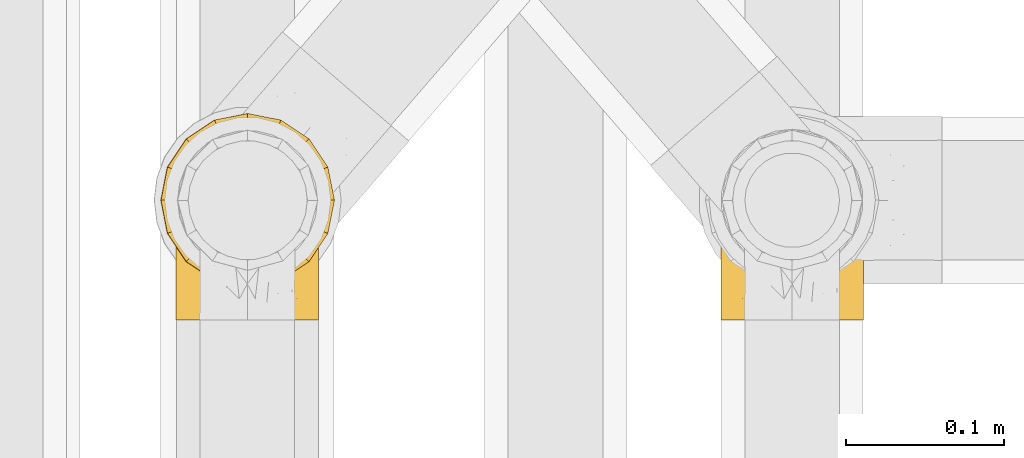
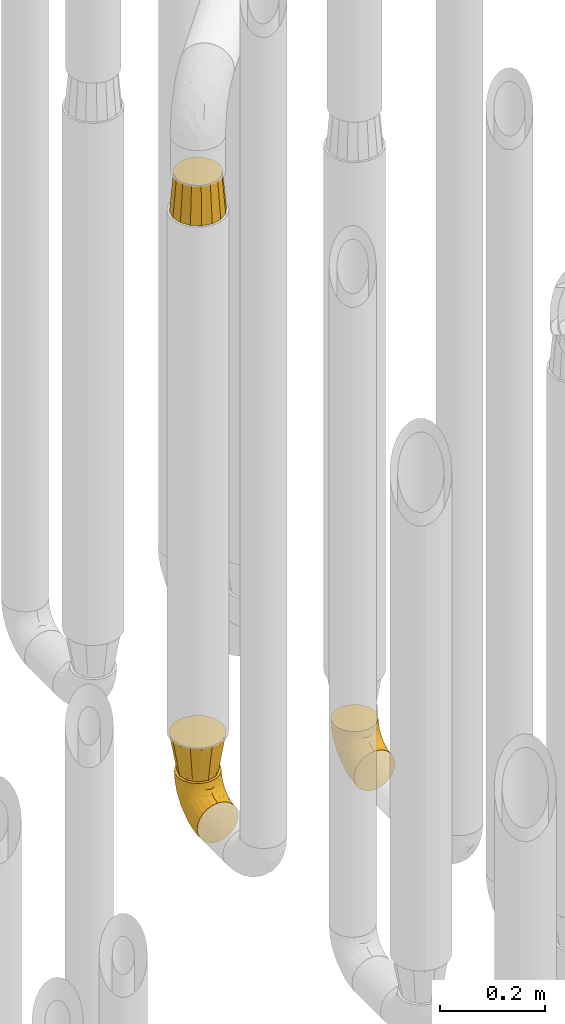
# One storey, part 229 of 827: 4 coverings.
"""IFC2X3 building model written with IfcOpenShell, lengths in millimetres."""

import ifcopenshell
import ifcopenshell.guid

model = None  # the IFC model being written
_history = None  # IfcOwnerHistory: only IFC2X3 demands one
_inside = {}  # id of a spatial element -> (the spatial element, [elements in it])
_under = {}  # id of a project, library or spatial element -> (it, [spatial elements below it])
_declared = {}  # id of a project -> (the project, [libraries it declares])
_typed = {}  # id of a type object -> (the type object, [elements of that type])
_made_of = {}  # id of a material, layer set ... -> (it, [elements and type objects made of it])


def new_model(schema):
    """Start an empty IFC model of exactly this schema.

    Asked for "IFC4X3", IfcOpenShell would pick the latest addendum, in which some entities
    have other attributes; the version numbers below select the first issue.
    IFC2X3 requires an IfcOwnerHistory on every rooted entity: one is made here for all.
    """
    global model, _history
    if schema == "IFC4X3":
        model = ifcopenshell.file(schema_version=(4, 3, 0, 0))
    else:
        model = ifcopenshell.file(schema=schema)
    _inside.clear()
    _under.clear()
    _declared.clear()
    _typed.clear()
    _made_of.clear()
    _history = None
    if model.schema == "IFC2X3":
        org = make("IfcOrganization", Name="unknown")
        user = make(
            "IfcPersonAndOrganization",
            ThePerson=make("IfcPerson", FamilyName="unknown"),
            TheOrganization=org,
        )
        app = make(
            "IfcApplication",
            ApplicationDeveloper=org,
            Version="unknown",
            ApplicationFullName="unknown",
            ApplicationIdentifier="unknown",
        )
        _history = make(
            "IfcOwnerHistory",
            OwningUser=user,
            OwningApplication=app,
            ChangeAction="ADDED",
            CreationDate=0,
        )
    return model


def make(cls, **values):
    """One entity of the class cls with the attributes given. An attribute that is None is left unset."""
    return model.create_entity(
        cls, **{name: value for name, value in values.items() if value is not None}
    )


def entity(cls, *values):
    """Any entity or typed value of the class cls, its attributes in the order of the schema. None: left unset."""
    e = model.create_entity(cls)
    for i, value in enumerate(values):
        if value is not None:
            e[i] = value
    return e


def rooted(cls, **values):
    """An entity with a GlobalId (a new one), such as an element, a storey or a relation."""
    return make(cls, GlobalId=ifcopenshell.guid.new(), OwnerHistory=_history, **values)


def si_unit(unit_type, name, prefix=None):
    """IfcSIUnit, for example si_unit("LENGTHUNIT", "METRE", prefix="MILLI")."""
    return make("IfcSIUnit", UnitType=unit_type, Prefix=prefix, Name=name)


def converted_unit(unit_type, name, factor, base, dimensions=None, offset=None):
    """IfcConversionBasedUnit, such as the inch: factor (a typed value) times the base unit."""
    return make(
        "IfcConversionBasedUnit"
        if offset is None
        else "IfcConversionBasedUnitWithOffset",
        ConversionOffset=offset,
        Dimensions=None
        if dimensions is None
        else entity("IfcDimensionalExponents", *dimensions),
        UnitType=unit_type,
        Name=name,
        ConversionFactor=make(
            "IfcMeasureWithUnit", ValueComponent=factor, UnitComponent=base
        ),
    )


def derived_unit(unit_type, elements):
    """IfcDerivedUnit: a product of units, each with its exponent."""
    return make(
        "IfcDerivedUnit",
        Elements=[
            make("IfcDerivedUnitElement", Unit=unit, Exponent=power)
            for unit, power in elements
        ],
        UnitType=unit_type,
    )


def assignment(units):
    """IfcUnitAssignment: the units of a project."""
    return None if units is None else make("IfcUnitAssignment", Units=units)


def point(xyz):
    """IfcCartesianPoint."""
    return None if xyz is None else make("IfcCartesianPoint", Coordinates=xyz)


def direction(xyz):
    """IfcDirection."""
    return None if xyz is None else make("IfcDirection", DirectionRatios=xyz)


def frame(location, z_axis=None, x_axis=None):
    """IfcAxis2Placement3D, a coordinate frame: its origin and axes. An axis left out is left unset."""
    return make(
        "IfcAxis2Placement3D",
        Location=point(location),
        Axis=direction(z_axis),
        RefDirection=direction(x_axis),
    )


def origin():
    """The frame at (0, 0, 0) with its axes left unset."""
    return frame((0.0, 0.0, 0.0))


def place(relative_to, where):
    """IfcLocalPlacement: puts the frame where relative to a parent placement (None: the world)."""
    return make(
        "IfcLocalPlacement", PlacementRelTo=relative_to, RelativePlacement=where
    )


def context(
    kind, dimensions, precision=None, world=None, true_north=None, identifier=None
):
    """IfcGeometricRepresentationContext, for example the 3D "Model" context."""
    return make(
        "IfcGeometricRepresentationContext",
        ContextIdentifier=identifier,
        ContextType=kind,
        CoordinateSpaceDimension=dimensions,
        Precision=precision,
        WorldCoordinateSystem=world,
        TrueNorth=true_north,
    )


def subcontext(parent, identifier, kind, view, scale=None):
    """IfcGeometricRepresentationSubContext, for example "Body" below "Model"."""
    return make(
        "IfcGeometricRepresentationSubContext",
        ContextIdentifier=identifier,
        ContextType=kind,
        ParentContext=parent,
        TargetScale=scale,
        TargetView=view,
    )


def project(units=None, contexts=None):
    """IfcProject with its units and contexts."""
    return rooted(
        "IfcProject",
        Name="project",
        RepresentationContexts=contexts,
        UnitsInContext=assignment(units),
    )


def spatial(cls, under=None, at=None, **own):
    """A site, building, storey or space (cls), placed at a placement, below another one or the project."""
    s = rooted(cls, ObjectPlacement=at, **own)
    if under is not None:
        _under.setdefault(under.id(), (under, []))[1].append(s)
    return s


def faces_of(points, faces, orient=None, outer=None):
    """IfcFace entities. A face is a list of loops; a loop is a list of indices into points, from 0.

    orient and outer hold one flag for each loop. By default every Orientation is true, the
    first loop of a face is its IfcFaceOuterBound and the others are IfcFaceBound.
    """
    made = []
    for i, loops in enumerate(faces):
        bounds = []
        for j, loop in enumerate(loops):
            is_outer = j == 0 if outer is None else outer[i][j]
            bounds.append(
                make(
                    "IfcFaceOuterBound" if is_outer else "IfcFaceBound",
                    Bound=make("IfcPolyLoop", Polygon=[points[k] for k in loop]),
                    Orientation=True if orient is None else orient[i][j],
                )
            )
        made.append(make("IfcFace", Bounds=bounds))
    return made


def faceted_brep(points, faces, orient=None, outer=None, voids=None):
    """IfcFacetedBrep: a solid bounded by flat faces; with voids (closed shells), ...WithVoids."""
    shared = [point(p) for p in points]
    hull = make("IfcClosedShell", CfsFaces=faces_of(shared, faces, orient, outer))
    if voids is None:
        return make("IfcFacetedBrep", Outer=hull)
    return make(
        "IfcFacetedBrepWithVoids",
        Outer=hull,
        Voids=[
            make(cls, CfsFaces=faces_of(shared, fs, o, b)) for cls, fs, o, b in voids
        ],
    )


def shape(context_of_items, identifier, shape_type, items):
    """IfcShapeRepresentation: the items that make up one representation, for example the "Body"."""
    return make(
        "IfcShapeRepresentation",
        ContextOfItems=context_of_items,
        RepresentationIdentifier=identifier,
        RepresentationType=shape_type,
        Items=items,
    )


def made_of(thing, what):
    """Note that an element or type object is made of a material, layer set ...; save() writes the relation."""
    if what is not None:
        _made_of.setdefault(what.id(), (what, []))[1].append(thing)
    return thing


def element(
    cls,
    number,
    at=None,
    inside=None,
    cuts=None,
    type_object=None,
    material=None,
    context=None,
    identifier="Body",
    shape_type=None,
    held_by="IfcProductDefinitionShape",
    body=None,
    shapes=None,
    **own,
):
    """One element of the class cls, such as IfcWall. Its Tag is "e" and its number.

    at: its placement. inside: the storey or other place that contains it. cuts: it is an
    opening in that element (IfcRelVoidsElement). A single representation is given by context,
    identifier, shape_type and body (its items); several are given by shapes. held_by: the class
    of the entity that holds the representations. save() writes the other relations.
    """
    e = rooted(cls, Tag="e%d" % number, ObjectPlacement=at, **own)
    if body is not None:
        shapes = [shape(context, identifier, shape_type, body)]
    if shapes is not None:
        e.Representation = make(held_by, Representations=shapes)
    if inside is not None:
        _inside.setdefault(inside.id(), (inside, []))[1].append(e)
    if cuts is not None:
        rooted(
            "IfcRelVoidsElement", RelatingBuildingElement=cuts, RelatedOpeningElement=e
        )
    if type_object is not None:
        _typed.setdefault(type_object.id(), (type_object, []))[1].append(e)
    return made_of(e, material)


def aggregate(whole, parts):
    """IfcRelAggregates: a whole, such as a stair, and the parts it consists of."""
    return rooted("IfcRelAggregates", RelatingObject=whole, RelatedObjects=parts)


def save(model, path):
    """Write the relations noted so far, then the file.

    IfcRelAggregates (storeys below a building ...), IfcRelContainedInSpatialStructure (elements
    in a storey), IfcRelDefinesByType, IfcRelAssociatesMaterial and IfcRelDeclares: one each for
    every whole, place, type object, material and project.
    """
    for whole, parts in _under.values():
        aggregate(whole, parts)
    for where, things in _inside.values():
        rooted(
            "IfcRelContainedInSpatialStructure",
            RelatedElements=things,
            RelatingStructure=where,
        )
    for kind, things in _typed.values():
        rooted("IfcRelDefinesByType", RelatedObjects=things, RelatingType=kind)
    for what, things in _made_of.values():
        rooted("IfcRelAssociatesMaterial", RelatedObjects=things, RelatingMaterial=what)
    for by, libraries in _declared.values():
        rooted("IfcRelDeclares", RelatingContext=by, RelatedDefinitions=libraries)
    model.write(path)


model = new_model("IFC2X3")

# Units and contexts
model_context = context("Model", 3, precision=0.01, world=origin(), true_north=direction((6.12303176911189e-17, 1.0)))
body_context = subcontext(model_context, "Body", "Model", "MODEL_VIEW")
ifc_project = project(units=[si_unit("LENGTHUNIT", "METRE", prefix="MILLI"), si_unit("AREAUNIT", "SQUARE_METRE"), si_unit("VOLUMEUNIT", "CUBIC_METRE"), converted_unit("PLANEANGLEUNIT", "DEGREE", entity("IfcRatioMeasure", 0.0174532925199433), si_unit("PLANEANGLEUNIT", "RADIAN"), dimensions=[0, 0, 0, 0, 0, 0, 0]), si_unit("MASSUNIT", "GRAM", prefix="KILO"), derived_unit("MASSDENSITYUNIT", [(si_unit("MASSUNIT", "GRAM", prefix="KILO"), 1), (si_unit("LENGTHUNIT", "METRE"), -3)]), derived_unit("MOMENTOFINERTIAUNIT", [(si_unit("LENGTHUNIT", "METRE"), 4)]), si_unit("TIMEUNIT", "SECOND"), si_unit("FREQUENCYUNIT", "HERTZ"), si_unit("THERMODYNAMICTEMPERATUREUNIT", "DEGREE_CELSIUS"), derived_unit("THERMALTRANSMITTANCEUNIT", [(si_unit("MASSUNIT", "GRAM", prefix="KILO"), 1), (si_unit("THERMODYNAMICTEMPERATUREUNIT", "KELVIN"), -1), (si_unit("TIMEUNIT", "SECOND"), -3)]), derived_unit("VOLUMETRICFLOWRATEUNIT", [(si_unit("LENGTHUNIT", "METRE"), 3), (si_unit("TIMEUNIT", "SECOND"), -1)]), derived_unit("MASSFLOWRATEUNIT", [(si_unit("MASSUNIT", "GRAM", prefix="KILO"), 1), (si_unit("TIMEUNIT", "SECOND"), -1)]), derived_unit("ROTATIONALFREQUENCYUNIT", [(si_unit("TIMEUNIT", "SECOND"), -1)]), si_unit("ELECTRICCURRENTUNIT", "AMPERE"), si_unit("ELECTRICVOLTAGEUNIT", "VOLT"), si_unit("POWERUNIT", "WATT"), si_unit("FORCEUNIT", "NEWTON", prefix="KILO"), si_unit("ILLUMINANCEUNIT", "LUX"), si_unit("LUMINOUSFLUXUNIT", "LUMEN"), si_unit("LUMINOUSINTENSITYUNIT", "CANDELA"), derived_unit("USERDEFINED", [(si_unit("MASSUNIT", "GRAM", prefix="KILO"), -1), (si_unit("LENGTHUNIT", "METRE"), -2), (si_unit("TIMEUNIT", "SECOND"), 3), (si_unit("LUMINOUSFLUXUNIT", "LUMEN"), 1)]), derived_unit("LINEARVELOCITYUNIT", [(si_unit("LENGTHUNIT", "METRE"), 1), (si_unit("TIMEUNIT", "SECOND"), -1)]), si_unit("PRESSUREUNIT", "PASCAL"), derived_unit("USERDEFINED", [(si_unit("LENGTHUNIT", "METRE"), -2), (si_unit("MASSUNIT", "GRAM", prefix="KILO"), 1), (si_unit("TIMEUNIT", "SECOND"), -2)]), derived_unit("LINEARFORCEUNIT", [(si_unit("MASSUNIT", "GRAM", prefix="KILO"), 1), (si_unit("LENGTHUNIT", "METRE"), 1), (si_unit("TIMEUNIT", "SECOND"), -2), (si_unit("LENGTHUNIT", "METRE"), -1)]), derived_unit("PLANARFORCEUNIT", [(si_unit("MASSUNIT", "GRAM", prefix="KILO"), 1), (si_unit("LENGTHUNIT", "METRE"), 1), (si_unit("TIMEUNIT", "SECOND"), -2), (si_unit("LENGTHUNIT", "METRE"), -2)])], contexts=[model_context])

# Site, building, storey
site_placement = place(None, origin())
site = spatial("IfcSite", under=ifc_project, at=site_placement, CompositionType="ELEMENT")
building_placement = place(site_placement, origin())
building = spatial("IfcBuilding", under=site, at=building_placement, CompositionType="ELEMENT")
storey_placement = place(building_placement, frame((0.0, 0.0, 28200.0)))
storey = spatial("IfcBuildingStorey", under=building, at=storey_placement, Name="08", CompositionType="ELEMENT", Elevation=28200.0)

# Coverings
covering_1_placement = place(storey_placement, frame((36928.29, 12503.58, 353.25)))
element("IfcCovering", 1, at=covering_1_placement, inside=storey, Name=":ADSK_", ObjectType=":ADSK_", PredefinedType="INSULATION", context=body_context, shape_type="Brep", body=[
    faceted_brep([(90.76, 87.65, 122.75), (87.42, 97.19, 122.75), (82.04, 105.75, 122.75), (74.89, 112.9, 122.75), (66.33, 118.28, 122.75), (56.79, 121.61, 122.75), (46.75, 122.75, 122.75), (36.69, 121.61, 122.75), (27.15, 118.27, 122.75), (18.59, 112.89, 122.75), (11.44, 105.74, 122.75), (6.06, 97.18, 122.75), (2.73, 87.64, 122.75), (1.6, 77.6, 122.75), (2.73, 67.54, 122.75), (6.07, 58.0, 122.75), (11.45, 49.44, 122.75), (18.6, 42.29, 122.75), (27.16, 36.91, 122.75), (36.7, 33.58, 122.75), (46.75, 32.45, 122.75), (56.8, 33.58, 122.75), (66.34, 36.92, 122.75), (74.9, 42.3, 122.75), (82.05, 49.45, 122.75), (87.43, 58.01, 122.75), (90.76, 67.55, 122.75), (91.9, 77.6, 122.75), (35.06, 1.6, 90.36), (24.17, 1.6, 85.85), (14.82, 1.6, 78.67), (7.64, 1.6, 69.32), (3.13, 1.6, 58.43), (1.6, 1.6, 46.75), (3.13, 1.6, 35.06), (7.64, 1.6, 24.17), (14.82, 1.6, 14.82), (24.17, 1.6, 7.64), (35.06, 1.6, 3.13), (46.75, 1.6, 1.6), (58.43, 1.6, 3.13), (69.32, 1.6, 7.64), (78.67, 1.6, 14.82), (85.85, 1.6, 24.17), (90.36, 1.6, 35.06), (91.9, 1.6, 46.75), (90.36, 1.6, 58.43), (85.85, 1.6, 69.32), (78.67, 1.6, 78.67), (69.32, 1.6, 85.85), (58.43, 1.6, 90.36), (46.75, 1.6, 91.9), (46.75, 99.61, 51.54), (55.2, 95.26, 47.17), (46.75, 86.21, 38.13), (46.75, 39.03, 7.52), (54.53, 30.75, 5.85), (46.75, 23.8, 5.11), (59.63, 60.8, 19.2), (62.07, 85.37, 38.98), (71.86, 73.64, 35.02), (62.65, 31.01, 8.21), (71.33, 49.14, 19.28), (72.93, 23.88, 12.19), (91.2, 82.74, 101.39), (86.31, 43.48, 34.43), (80.89, 29.47, 20.95), (79.49, 56.38, 30.74), (90.68, 72.18, 72.93), (86.84, 72.24, 56.64), (87.38, 87.6, 80.81), (76.87, 107.24, 93.43), (83.73, 101.1, 100.76), (81.03, 95.16, 74.27), (91.9, 71.81, 93.66), (91.9, 63.57, 81.33), (91.9, 55.34, 69.01), (91.03, 23.66, 40.87), (87.58, 20.55, 29.38), (56.52, 107.97, 67.05), (46.75, 116.82, 85.31), (60.4, 117.03, 93.68), (91.9, 30.68, 52.53), (91.9, 21.51, 50.71), (91.9, 12.33, 48.88), (67.87, 106.17, 72.77), (90.35, 52.37, 51.21), (69.57, 114.51, 101.18), (46.75, 119.23, 100.54), (79.91, 78.37, 48.74), (91.9, 75.46, 112.01), (91.9, 73.63, 102.83), (74.99, 101.51, 73.88), (46.75, 72.81, 24.73), (91.9, 43.01, 60.77), (88.53, 92.6, 103.08), (72.65, 91.86, 54.8), (46.75, 55.92, 16.13), (62.97, 99.01, 55.92), (46.75, 108.21, 68.42), (66.2, 32.05, 104.98), (56.6, 30.22, 108.58), (59.89, 23.37, 98.21), (90.95, 28.43, 61.56), (90.22, 16.44, 60.69), (76.64, 37.1, 100.0), (71.58, 28.88, 95.88), (79.99, 33.93, 90.81), (89.54, 50.17, 84.88), (89.97, 40.57, 73.29), (81.32, 47.62, 113.4), (74.56, 39.9, 109.8), (84.15, 47.92, 102.13), (90.37, 34.27, 67.29), (87.82, 24.65, 70.34), (90.98, 62.6, 95.15), (90.96, 66.18, 105.49), (85.14, 11.74, 71.5), (58.11, 13.89, 92.87), (46.75, 17.02, 96.03), (78.39, 15.86, 81.34), (88.22, 57.71, 107.44), (66.06, 9.11, 88.36), (68.6, 18.55, 90.43), (63.78, 34.74, 114.37), (88.42, 54.95, 98.41), (90.61, 57.35, 88.73), (83.8, 22.03, 76.89), (77.98, 24.8, 86.08), (91.22, 69.07, 112.64), (83.46, 42.31, 94.21), (46.75, 29.63, 112.22), (46.75, 28.31, 107.32), (84.66, 30.23, 79.95), (86.33, 40.13, 84.51), (46.75, 22.67, 101.67), (46.75, 12.12, 94.71), (15.1, 15.86, 81.34), (9.69, 22.03, 76.89), (15.52, 24.8, 86.08), (8.83, 30.23, 79.96), (35.39, 13.88, 92.87), (12.18, 47.61, 113.41), (1.6, 73.63, 102.83), (2.53, 66.17, 105.5), (2.27, 69.07, 112.64), (36.9, 30.22, 108.58), (27.31, 32.04, 104.98), (33.62, 23.36, 98.2), (5.07, 54.93, 98.4), (9.36, 47.91, 102.13), (5.27, 57.69, 107.44), (27.43, 9.1, 88.36), (1.6, 21.51, 50.71), (1.6, 12.33, 48.88), (10.05, 42.29, 94.22), (16.87, 37.09, 100.01), (8.35, 11.74, 71.5), (3.27, 16.44, 60.69), (1.6, 30.68, 52.53), (21.94, 28.86, 95.89), (29.72, 34.74, 114.37), (1.6, 63.57, 81.33), (1.6, 55.34, 69.01), (3.96, 50.17, 84.88), (1.6, 75.46, 112.01), (18.95, 39.89, 109.8), (2.54, 28.43, 61.56), (3.12, 34.27, 67.29), (1.6, 43.01, 60.77), (2.51, 62.59, 95.14), (3.52, 40.57, 73.29), (7.17, 40.13, 84.53), (1.6, 71.81, 93.66), (13.52, 33.92, 90.82), (2.88, 57.34, 88.73), (5.67, 24.65, 70.34), (24.89, 18.54, 90.43), (12.6, 29.47, 20.95), (7.18, 43.48, 34.43), (14.0, 56.4, 30.74), (22.16, 49.17, 19.29), (21.61, 73.69, 35.07), (3.14, 52.37, 51.21), (6.65, 72.26, 56.67), (20.82, 91.88, 54.85), (31.41, 85.36, 38.98), (5.91, 20.55, 29.38), (2.46, 23.66, 40.87), (33.87, 60.8, 19.2), (30.84, 31.02, 8.21), (38.96, 30.75, 5.85), (20.56, 23.9, 12.19), (2.81, 72.17, 72.93), (6.1, 87.59, 80.83), (2.29, 82.74, 101.39), (33.08, 117.03, 93.69), (16.61, 107.23, 93.43), (36.96, 107.97, 67.04), (9.75, 101.08, 100.76), (25.61, 106.17, 72.78), (30.5, 99.01, 55.93), (23.91, 114.5, 101.18), (12.45, 95.15, 74.27), (18.49, 101.5, 73.89), (4.96, 92.59, 103.09), (13.56, 78.38, 48.78), (38.28, 95.27, 47.19)], [[[0, 1, 2, 3, 4, 5, 6, 7, 8, 9, 10, 11, 12, 13, 14, 15, 16, 17, 18, 19, 20, 21, 22, 23, 24, 25, 26, 27]], [[28, 29, 30, 31, 32, 33, 34, 35, 36, 37, 38, 39, 40, 41, 42, 43, 44, 45, 46, 47, 48, 49, 50, 51]], [[52, 53, 54]], [[55, 56, 57]], [[58, 59, 60]], [[61, 62, 63]], [[27, 64, 0]], [[65, 66, 67]], [[41, 40, 61]], [[68, 69, 70]], [[66, 43, 42]], [[63, 42, 41]], [[71, 72, 73]], [[72, 2, 1]], [[68, 74, 75, 76]], [[45, 44, 77]], [[43, 78, 44]], [[79, 80, 81]], [[77, 82, 83, 84, 45]], [[79, 81, 85]], [[71, 2, 72]], [[65, 86, 77]], [[4, 81, 5]], [[66, 65, 78]], [[4, 3, 87]], [[81, 88, 5]], [[63, 66, 42]], [[68, 70, 64]], [[67, 60, 89]], [[71, 3, 2]], [[64, 27, 90, 91, 74]], [[92, 71, 73]], [[40, 57, 56]], [[59, 93, 54]], [[86, 76, 94, 82]], [[1, 0, 95]], [[58, 62, 61]], [[60, 96, 89]], [[85, 81, 87]], [[56, 97, 58]], [[65, 67, 69]], [[87, 81, 4]], [[67, 89, 69]], [[61, 63, 41]], [[95, 72, 1]], [[73, 72, 70]], [[69, 73, 70]], [[73, 89, 96]], [[3, 71, 87]], [[85, 87, 71]], [[58, 61, 56]], [[59, 58, 93]], [[76, 86, 68]], [[69, 89, 73]], [[68, 86, 69]], [[65, 69, 86]], [[68, 64, 74]], [[95, 64, 70]], [[98, 79, 85]], [[79, 52, 99, 80]], [[66, 62, 67]], [[62, 58, 60]], [[62, 60, 67]], [[59, 98, 96]], [[59, 96, 60]], [[96, 85, 92]], [[88, 81, 80]], [[88, 6, 5]], [[66, 63, 62]], [[64, 95, 0]], [[72, 95, 70]], [[77, 44, 78]], [[86, 82, 77]], [[40, 39, 57]], [[96, 98, 85]], [[40, 56, 61]], [[66, 78, 43]], [[77, 78, 65]], [[79, 98, 53]], [[96, 92, 73]], [[85, 71, 92]], [[97, 56, 55]], [[97, 93, 58]], [[53, 98, 59]], [[54, 53, 59]], [[79, 53, 52]], [[100, 101, 102]], [[46, 45, 84, 83]], [[103, 104, 82]], [[82, 104, 83]], [[105, 106, 107]], [[108, 109, 76]], [[110, 111, 112]], [[103, 113, 114]], [[115, 74, 116]], [[48, 47, 117]], [[118, 102, 119]], [[49, 48, 120]], [[74, 91, 116]], [[116, 121, 115]], [[49, 122, 50]], [[123, 106, 102]], [[124, 111, 22]], [[125, 126, 115]], [[23, 22, 111]], [[24, 110, 121]], [[120, 127, 128]], [[90, 26, 129]], [[27, 26, 90]], [[121, 125, 115]], [[24, 121, 25]], [[130, 105, 107]], [[129, 25, 116]], [[21, 20, 131]], [[120, 123, 122]], [[112, 105, 130]], [[50, 118, 51]], [[21, 124, 22]], [[101, 131, 132]], [[117, 120, 48]], [[24, 23, 110]], [[127, 114, 133]], [[75, 108, 76]], [[107, 134, 130]], [[133, 114, 113]], [[129, 116, 91]], [[25, 121, 116]], [[121, 112, 125]], [[75, 74, 115]], [[101, 135, 102]], [[131, 101, 21]], [[101, 100, 124]], [[128, 127, 133]], [[119, 136, 51, 118]], [[104, 47, 46]], [[83, 104, 46]], [[117, 104, 114]], [[101, 124, 21]], [[111, 124, 100]], [[102, 118, 123]], [[133, 134, 107]], [[111, 110, 23]], [[114, 104, 103]], [[94, 76, 109]], [[121, 110, 112]], [[122, 118, 50]], [[134, 109, 108]], [[133, 107, 128]], [[112, 108, 125]], [[126, 125, 108]], [[108, 75, 126]], [[75, 115, 126]], [[109, 134, 133]], [[130, 108, 112]], [[108, 130, 134]], [[105, 112, 111]], [[111, 100, 105]], [[106, 105, 100]], [[102, 106, 100]], [[128, 106, 123]], [[90, 129, 91]], [[25, 129, 26]], [[104, 117, 47]], [[117, 114, 127]], [[82, 94, 103]], [[113, 94, 109]], [[94, 113, 103]], [[133, 113, 109]], [[106, 128, 107]], [[123, 120, 128]], [[120, 122, 49]], [[118, 122, 123]], [[135, 101, 132]], [[135, 119, 102]], [[117, 127, 120]], [[30, 29, 137]], [[138, 139, 140]], [[51, 136, 119, 141]], [[142, 17, 16]], [[143, 144, 145]], [[146, 147, 148]], [[149, 150, 151]], [[152, 29, 28]], [[33, 32, 153, 154]], [[150, 155, 156]], [[157, 31, 30]], [[153, 158, 159]], [[29, 152, 137]], [[148, 141, 119]], [[156, 160, 147]], [[148, 135, 146]], [[137, 138, 157]], [[19, 161, 146]], [[162, 163, 164]], [[14, 13, 165]], [[153, 32, 158]], [[147, 161, 166]], [[18, 17, 166]], [[167, 168, 169]], [[166, 150, 156]], [[151, 150, 142]], [[151, 170, 149]], [[151, 16, 15]], [[171, 140, 172]], [[165, 143, 145]], [[173, 170, 144]], [[142, 166, 17]], [[19, 131, 20]], [[144, 170, 151]], [[18, 161, 19]], [[173, 144, 143]], [[140, 139, 174]], [[171, 164, 163]], [[164, 172, 155]], [[151, 15, 144]], [[145, 15, 14]], [[173, 162, 170]], [[149, 175, 164]], [[19, 146, 131]], [[132, 131, 146]], [[160, 148, 147]], [[159, 158, 167]], [[135, 132, 146]], [[158, 32, 31]], [[157, 158, 31]], [[167, 158, 176]], [[166, 161, 18]], [[146, 161, 147]], [[148, 177, 141]], [[171, 168, 140]], [[171, 163, 169]], [[151, 142, 16]], [[166, 142, 150]], [[152, 141, 177]], [[51, 141, 28]], [[138, 140, 176]], [[172, 140, 174]], [[175, 149, 170]], [[164, 150, 149]], [[170, 162, 175]], [[162, 164, 175]], [[155, 172, 174]], [[171, 172, 164]], [[155, 174, 156]], [[164, 155, 150]], [[160, 156, 174]], [[147, 166, 156]], [[139, 160, 174]], [[148, 160, 177]], [[15, 145, 144]], [[165, 145, 14]], [[137, 157, 30]], [[158, 157, 176]], [[168, 167, 176]], [[169, 159, 167]], [[140, 168, 176]], [[169, 168, 171]], [[137, 177, 139]], [[160, 139, 177]], [[141, 152, 28]], [[137, 152, 177]], [[148, 119, 135]], [[157, 138, 176]], [[139, 138, 137]], [[178, 179, 180]], [[181, 180, 182]], [[179, 183, 184]], [[185, 186, 182]], [[187, 188, 179]], [[188, 33, 154, 153, 159]], [[181, 189, 190]], [[35, 34, 187]], [[191, 38, 190]], [[192, 178, 181]], [[179, 184, 180]], [[192, 190, 37]], [[37, 190, 38]], [[36, 35, 178]], [[54, 93, 186]], [[35, 187, 178]], [[193, 194, 184]], [[195, 173, 143, 165, 13]], [[195, 193, 173]], [[193, 163, 162, 173]], [[13, 12, 195]], [[8, 7, 196]], [[9, 197, 10]], [[198, 80, 99, 52]], [[196, 7, 88]], [[197, 199, 10]], [[182, 189, 181]], [[200, 198, 201]], [[200, 196, 198]], [[9, 8, 202]], [[194, 199, 203]], [[192, 37, 36]], [[80, 196, 88]], [[183, 159, 169, 163]], [[188, 34, 33]], [[202, 200, 197]], [[185, 203, 204]], [[202, 8, 196]], [[10, 199, 11]], [[12, 11, 205]], [[38, 191, 57]], [[189, 97, 191]], [[203, 199, 197]], [[205, 199, 194]], [[204, 203, 197]], [[184, 203, 206]], [[200, 202, 196]], [[197, 9, 202]], [[207, 54, 186]], [[97, 55, 191]], [[194, 203, 184]], [[183, 163, 193]], [[184, 206, 180]], [[183, 193, 184]], [[205, 195, 12]], [[193, 195, 194]], [[80, 198, 196]], [[207, 186, 201]], [[182, 180, 206]], [[181, 178, 180]], [[185, 182, 206]], [[182, 186, 189]], [[203, 185, 206]], [[185, 200, 201]], [[7, 6, 88]], [[178, 192, 36]], [[190, 192, 181]], [[199, 205, 11]], [[195, 205, 194]], [[159, 183, 188]], [[179, 188, 183]], [[57, 191, 55]], [[57, 39, 38]], [[189, 191, 190]], [[188, 187, 34]], [[178, 187, 179]], [[186, 93, 189]], [[197, 200, 204]], [[185, 204, 200]], [[189, 93, 97]], [[207, 198, 52]], [[185, 201, 186]], [[198, 207, 201]], [[54, 207, 52]]]),
])
covering_2_placement = place(storey_placement, frame((36582.9, 12503.58, 353.25)))
element("IfcCovering", 2, at=covering_2_placement, inside=storey, Name=":ADSK_", ObjectType=":ADSK_", PredefinedType="INSULATION", context=body_context, shape_type="Brep", body=[
    faceted_brep([(90.78, 87.65, 122.74), (87.44, 97.19, 122.74), (82.05, 105.75, 122.74), (74.9, 112.9, 122.74), (66.34, 118.28, 122.74), (56.8, 121.61, 122.74), (46.76, 122.75, 122.75), (36.71, 121.61, 122.75), (27.16, 118.27, 122.75), (18.6, 112.89, 122.75), (11.46, 105.74, 122.75), (6.08, 97.18, 122.75), (2.74, 87.64, 122.75), (1.61, 77.6, 122.75), (2.74, 67.54, 122.75), (6.09, 58.0, 122.75), (11.47, 49.44, 122.75), (18.62, 42.29, 122.75), (27.18, 36.91, 122.75), (36.72, 33.58, 122.75), (46.76, 32.45, 122.75), (56.81, 33.58, 122.74), (66.36, 36.92, 122.74), (74.92, 42.3, 122.74), (82.07, 49.45, 122.74), (87.44, 58.01, 122.74), (90.78, 67.55, 122.74), (91.91, 77.6, 122.74), (35.07, 1.6, 90.36), (24.18, 1.6, 85.85), (14.83, 1.6, 78.68), (7.65, 1.6, 69.33), (3.14, 1.6, 58.44), (1.6, 1.6, 46.75), (3.13, 1.6, 35.07), (7.64, 1.6, 24.18), (14.81, 1.6, 14.83), (24.16, 1.6, 7.65), (35.05, 1.6, 3.14), (46.74, 1.6, 1.6), (58.42, 1.6, 3.13), (69.31, 1.6, 7.64), (78.66, 1.6, 14.81), (85.84, 1.6, 24.16), (90.35, 1.6, 35.05), (91.9, 1.6, 46.74), (90.36, 1.6, 58.42), (85.85, 1.6, 69.31), (78.68, 1.6, 78.66), (69.33, 1.6, 85.84), (58.44, 1.6, 90.35), (46.75, 1.6, 91.9), (46.75, 99.61, 51.54), (55.2, 95.26, 47.16), (46.74, 86.21, 38.13), (46.74, 39.03, 7.52), (54.52, 30.75, 5.85), (46.74, 23.8, 5.11), (59.62, 60.8, 19.2), (62.07, 85.37, 38.97), (71.86, 73.64, 35.01), (62.64, 31.01, 8.2), (71.32, 49.14, 19.27), (72.92, 23.88, 12.18), (91.21, 82.74, 101.38), (86.31, 43.48, 34.42), (80.89, 29.47, 20.95), (79.49, 56.38, 30.73), (90.69, 72.18, 72.92), (86.84, 72.24, 56.63), (87.39, 87.6, 80.8), (76.88, 107.24, 93.42), (83.74, 101.1, 100.76), (81.03, 95.16, 74.27), (91.9, 71.81, 93.65), (91.9, 63.57, 81.32), (91.9, 55.34, 69.0), (91.03, 23.66, 40.86), (87.58, 20.55, 29.38), (56.53, 107.97, 67.04), (46.75, 116.82, 85.31), (60.41, 117.03, 93.68), (91.9, 30.68, 52.52), (91.9, 21.51, 50.7), (91.9, 12.33, 48.87), (67.88, 106.17, 72.77), (90.35, 52.37, 51.2), (69.58, 114.51, 101.17), (46.76, 119.23, 100.54), (79.91, 78.37, 48.74), (91.91, 75.46, 112.0), (91.91, 73.63, 102.83), (75.0, 101.51, 73.88), (46.74, 72.81, 24.73), (91.9, 43.01, 60.76), (88.54, 92.6, 103.07), (72.65, 91.86, 54.79), (46.74, 55.92, 16.13), (62.98, 99.01, 55.92), (46.75, 108.21, 68.42), (66.21, 32.05, 104.97), (56.61, 30.22, 108.58), (59.9, 23.37, 98.2), (90.95, 28.43, 61.55), (90.22, 16.44, 60.69), (76.66, 37.1, 99.99), (71.59, 28.88, 95.88), (80.0, 33.93, 90.8), (89.54, 50.17, 84.87), (89.98, 40.57, 73.28), (81.33, 47.62, 113.4), (74.57, 39.9, 109.79), (84.16, 47.92, 102.12), (90.37, 34.27, 67.28), (87.82, 24.65, 70.33), (90.99, 62.6, 95.14), (90.97, 66.18, 105.48), (85.14, 11.74, 71.49), (58.11, 13.89, 92.87), (46.76, 17.02, 96.03), (78.4, 15.86, 81.33), (88.24, 57.71, 107.43), (66.07, 9.11, 88.36), (68.61, 18.55, 90.43), (63.79, 34.74, 114.37), (88.43, 54.95, 98.4), (90.62, 57.35, 88.72), (83.81, 22.03, 76.88), (77.99, 24.8, 86.07), (91.23, 69.07, 112.63), (83.47, 42.31, 94.2), (46.76, 29.63, 112.22), (46.76, 28.31, 107.32), (84.67, 30.23, 79.94), (86.34, 40.13, 84.5), (46.76, 22.67, 101.67), (46.75, 12.12, 94.71), (15.11, 15.86, 81.35), (9.7, 22.03, 76.89), (15.53, 24.8, 86.09), (8.84, 30.23, 79.96), (35.4, 13.88, 92.87), (12.2, 47.61, 113.41), (1.61, 73.63, 102.84), (2.55, 66.17, 105.5), (2.28, 69.07, 112.65), (36.91, 30.22, 108.58), (27.32, 32.04, 104.99), (33.63, 23.36, 98.21), (5.08, 54.93, 98.41), (9.37, 47.91, 102.14), (5.29, 57.69, 107.45), (27.44, 9.1, 88.37), (1.6, 21.51, 50.71), (1.6, 12.33, 48.89), (10.06, 42.29, 94.23), (16.88, 37.09, 100.01), (8.36, 11.74, 71.51), (3.28, 16.44, 60.7), (1.6, 30.68, 52.54), (21.95, 28.86, 95.89), (29.74, 34.74, 114.38), (1.6, 63.57, 81.34), (1.6, 55.34, 69.01), (3.97, 50.17, 84.89), (1.61, 75.46, 112.02), (18.96, 39.89, 109.81), (2.54, 28.43, 61.57), (3.12, 34.27, 67.3), (1.6, 43.01, 60.78), (2.52, 62.59, 95.15), (3.52, 40.57, 73.3), (7.18, 40.13, 84.54), (1.6, 71.81, 93.67), (13.53, 33.92, 90.83), (2.89, 57.34, 88.74), (5.68, 24.65, 70.35), (24.9, 18.54, 90.43), (12.59, 29.47, 20.96), (7.18, 43.48, 34.44), (14.0, 56.4, 30.75), (22.16, 49.17, 19.29), (21.61, 73.69, 35.07), (3.14, 52.37, 51.22), (6.65, 72.26, 56.67), (20.82, 91.88, 54.86), (31.41, 85.36, 38.98), (5.91, 20.55, 29.39), (2.46, 23.66, 40.87), (33.86, 60.8, 19.21), (30.84, 31.02, 8.21), (38.95, 30.75, 5.85), (20.55, 23.9, 12.2), (2.81, 72.17, 72.94), (6.11, 87.59, 80.84), (2.3, 82.74, 101.4), (33.09, 117.03, 93.69), (16.62, 107.23, 93.44), (36.96, 107.97, 67.04), (9.76, 101.08, 100.77), (25.61, 106.17, 72.79), (30.5, 99.01, 55.93), (23.92, 114.5, 101.18), (12.46, 95.15, 74.28), (18.49, 101.5, 73.89), (4.97, 92.59, 103.1), (13.57, 78.38, 48.78), (38.28, 95.27, 47.19)], [[[0, 1, 2, 3, 4, 5, 6, 7, 8, 9, 10, 11, 12, 13, 14, 15, 16, 17, 18, 19, 20, 21, 22, 23, 24, 25, 26, 27]], [[28, 29, 30, 31, 32, 33, 34, 35, 36, 37, 38, 39, 40, 41, 42, 43, 44, 45, 46, 47, 48, 49, 50, 51]], [[52, 53, 54]], [[55, 56, 57]], [[58, 59, 60]], [[61, 62, 63]], [[27, 64, 0]], [[65, 66, 67]], [[41, 40, 61]], [[68, 69, 70]], [[66, 43, 42]], [[63, 42, 41]], [[71, 72, 73]], [[72, 2, 1]], [[68, 74, 75, 76]], [[45, 44, 77]], [[43, 78, 44]], [[79, 80, 81]], [[77, 82, 83, 84, 45]], [[79, 81, 85]], [[71, 2, 72]], [[65, 86, 77]], [[4, 81, 5]], [[66, 65, 78]], [[4, 3, 87]], [[81, 88, 5]], [[63, 66, 42]], [[68, 70, 64]], [[67, 60, 89]], [[71, 3, 2]], [[64, 27, 90, 91, 74]], [[92, 71, 73]], [[40, 57, 56]], [[59, 93, 54]], [[86, 76, 94, 82]], [[1, 0, 95]], [[58, 62, 61]], [[60, 96, 89]], [[85, 81, 87]], [[56, 97, 58]], [[65, 67, 69]], [[87, 81, 4]], [[67, 89, 69]], [[61, 63, 41]], [[95, 72, 1]], [[73, 72, 70]], [[69, 73, 70]], [[73, 89, 96]], [[3, 71, 87]], [[85, 87, 71]], [[58, 61, 56]], [[59, 58, 93]], [[76, 86, 68]], [[69, 89, 73]], [[68, 86, 69]], [[65, 69, 86]], [[68, 64, 74]], [[95, 64, 70]], [[98, 79, 85]], [[79, 52, 99, 80]], [[66, 62, 67]], [[62, 58, 60]], [[62, 60, 67]], [[59, 98, 96]], [[59, 96, 60]], [[96, 85, 92]], [[88, 81, 80]], [[88, 6, 5]], [[66, 63, 62]], [[64, 95, 0]], [[72, 95, 70]], [[77, 44, 78]], [[86, 82, 77]], [[40, 39, 57]], [[96, 98, 85]], [[40, 56, 61]], [[66, 78, 43]], [[77, 78, 65]], [[79, 98, 53]], [[96, 92, 73]], [[85, 71, 92]], [[97, 56, 55]], [[97, 93, 58]], [[53, 98, 59]], [[54, 53, 59]], [[79, 53, 52]], [[100, 101, 102]], [[46, 45, 84, 83]], [[103, 104, 82]], [[82, 104, 83]], [[105, 106, 107]], [[108, 109, 76]], [[110, 111, 112]], [[103, 113, 114]], [[115, 74, 116]], [[48, 47, 117]], [[118, 102, 119]], [[49, 48, 120]], [[74, 91, 116]], [[116, 121, 115]], [[49, 122, 50]], [[123, 106, 102]], [[124, 111, 22]], [[125, 126, 115]], [[23, 22, 111]], [[24, 110, 121]], [[120, 127, 128]], [[90, 26, 129]], [[27, 26, 90]], [[121, 125, 115]], [[24, 121, 25]], [[130, 105, 107]], [[129, 25, 116]], [[21, 20, 131]], [[120, 123, 122]], [[112, 105, 130]], [[50, 118, 51]], [[21, 124, 22]], [[101, 131, 132]], [[117, 120, 48]], [[24, 23, 110]], [[127, 114, 133]], [[75, 108, 76]], [[107, 134, 130]], [[133, 114, 113]], [[129, 116, 91]], [[25, 121, 116]], [[121, 112, 125]], [[75, 74, 115]], [[101, 135, 102]], [[131, 101, 21]], [[101, 100, 124]], [[128, 127, 133]], [[119, 136, 51, 118]], [[104, 47, 46]], [[83, 104, 46]], [[117, 104, 114]], [[101, 124, 21]], [[111, 124, 100]], [[102, 118, 123]], [[133, 134, 107]], [[111, 110, 23]], [[114, 104, 103]], [[94, 76, 109]], [[121, 110, 112]], [[122, 118, 50]], [[134, 109, 108]], [[133, 107, 128]], [[112, 108, 125]], [[126, 125, 108]], [[108, 75, 126]], [[75, 115, 126]], [[109, 134, 133]], [[130, 108, 112]], [[108, 130, 134]], [[105, 112, 111]], [[111, 100, 105]], [[106, 105, 100]], [[102, 106, 100]], [[128, 106, 123]], [[90, 129, 91]], [[25, 129, 26]], [[104, 117, 47]], [[117, 114, 127]], [[82, 94, 103]], [[113, 94, 109]], [[94, 113, 103]], [[133, 113, 109]], [[106, 128, 107]], [[123, 120, 128]], [[120, 122, 49]], [[118, 122, 123]], [[135, 101, 132]], [[135, 119, 102]], [[117, 127, 120]], [[30, 29, 137]], [[138, 139, 140]], [[51, 136, 119, 141]], [[142, 17, 16]], [[143, 144, 145]], [[146, 147, 148]], [[149, 150, 151]], [[152, 29, 28]], [[33, 32, 153, 154]], [[150, 155, 156]], [[157, 31, 30]], [[153, 158, 159]], [[29, 152, 137]], [[148, 141, 119]], [[156, 160, 147]], [[148, 135, 146]], [[137, 138, 157]], [[19, 161, 146]], [[162, 163, 164]], [[14, 13, 165]], [[153, 32, 158]], [[147, 161, 166]], [[18, 17, 166]], [[167, 168, 169]], [[166, 150, 156]], [[151, 150, 142]], [[151, 170, 149]], [[151, 16, 15]], [[171, 140, 172]], [[165, 143, 145]], [[173, 170, 144]], [[142, 166, 17]], [[19, 131, 20]], [[144, 170, 151]], [[18, 161, 19]], [[173, 144, 143]], [[140, 139, 174]], [[171, 164, 163]], [[164, 172, 155]], [[151, 15, 144]], [[145, 15, 14]], [[173, 162, 170]], [[149, 175, 164]], [[19, 146, 131]], [[132, 131, 146]], [[160, 148, 147]], [[159, 158, 167]], [[135, 132, 146]], [[158, 32, 31]], [[157, 158, 31]], [[167, 158, 176]], [[166, 161, 18]], [[146, 161, 147]], [[148, 177, 141]], [[171, 168, 140]], [[171, 163, 169]], [[151, 142, 16]], [[166, 142, 150]], [[152, 141, 177]], [[51, 141, 28]], [[138, 140, 176]], [[172, 140, 174]], [[175, 149, 170]], [[164, 150, 149]], [[170, 162, 175]], [[162, 164, 175]], [[155, 172, 174]], [[171, 172, 164]], [[155, 174, 156]], [[164, 155, 150]], [[160, 156, 174]], [[147, 166, 156]], [[139, 160, 174]], [[148, 160, 177]], [[15, 145, 144]], [[165, 145, 14]], [[137, 157, 30]], [[158, 157, 176]], [[168, 167, 176]], [[169, 159, 167]], [[140, 168, 176]], [[169, 168, 171]], [[137, 177, 139]], [[160, 139, 177]], [[141, 152, 28]], [[137, 152, 177]], [[148, 119, 135]], [[157, 138, 176]], [[139, 138, 137]], [[178, 179, 180]], [[181, 180, 182]], [[179, 183, 184]], [[185, 186, 182]], [[187, 188, 179]], [[188, 33, 154, 153, 159]], [[181, 189, 190]], [[35, 34, 187]], [[191, 38, 190]], [[192, 178, 181]], [[179, 184, 180]], [[192, 190, 37]], [[37, 190, 38]], [[36, 35, 178]], [[54, 93, 186]], [[35, 187, 178]], [[193, 194, 184]], [[195, 173, 143, 165, 13]], [[195, 193, 173]], [[193, 163, 162, 173]], [[13, 12, 195]], [[8, 7, 196]], [[9, 197, 10]], [[198, 80, 99, 52]], [[196, 7, 88]], [[197, 199, 10]], [[182, 189, 181]], [[200, 198, 201]], [[200, 196, 198]], [[9, 8, 202]], [[194, 199, 203]], [[192, 37, 36]], [[80, 196, 88]], [[183, 159, 169, 163]], [[188, 34, 33]], [[202, 200, 197]], [[185, 203, 204]], [[202, 8, 196]], [[10, 199, 11]], [[12, 11, 205]], [[38, 191, 57]], [[189, 97, 191]], [[203, 199, 197]], [[205, 199, 194]], [[204, 203, 197]], [[184, 203, 206]], [[200, 202, 196]], [[197, 9, 202]], [[207, 54, 186]], [[97, 55, 191]], [[194, 203, 184]], [[183, 163, 193]], [[184, 206, 180]], [[183, 193, 184]], [[205, 195, 12]], [[193, 195, 194]], [[80, 198, 196]], [[207, 186, 201]], [[182, 180, 206]], [[181, 178, 180]], [[185, 182, 206]], [[182, 186, 189]], [[203, 185, 206]], [[185, 200, 201]], [[7, 6, 88]], [[178, 192, 36]], [[190, 192, 181]], [[199, 205, 11]], [[195, 205, 194]], [[159, 183, 188]], [[179, 188, 183]], [[57, 191, 55]], [[57, 39, 38]], [[189, 191, 190]], [[188, 187, 34]], [[178, 187, 179]], [[186, 93, 189]], [[197, 200, 204]], [[185, 204, 200]], [[189, 93, 97]], [[207, 198, 52]], [[185, 201, 186]], [[198, 207, 201]], [[54, 207, 52]]]),
])
covering_3_placement = place(storey_placement, frame((36573.08, 12524.58, 475.99)))
element("IfcCovering", 3, at=covering_3_placement, inside=storey, Name=":ADSK_", ObjectType=":ADSK_", PredefinedType="INSULATION", context=body_context, shape_type="Brep", body=[
    faceted_brep([(17.7, 95.49, 89.02), (11.74, 86.56, 89.02), (5.78, 77.64, 89.02), (3.69, 67.12, 89.02), (1.6, 56.6, 89.02), (3.69, 46.07, 89.02), (5.78, 35.55, 89.02), (11.74, 26.63, 89.02), (17.7, 17.7, 89.02), (26.63, 11.74, 89.01), (35.55, 5.78, 89.01), (46.07, 3.69, 89.01), (56.6, 1.6, 89.01), (67.12, 3.69, 89.01), (77.64, 5.78, 89.0), (86.56, 11.74, 89.0), (95.49, 17.7, 89.0), (101.45, 26.63, 89.0), (107.41, 35.55, 89.0), (109.5, 46.07, 89.0), (111.6, 56.6, 89.0), (109.5, 67.12, 89.0), (107.41, 77.64, 89.0), (101.45, 86.56, 89.0), (95.49, 95.49, 89.0), (86.56, 101.45, 89.0), (77.64, 107.41, 89.0), (67.12, 109.5, 89.01), (56.6, 111.6, 89.01), (46.07, 109.5, 89.01), (35.55, 107.41, 89.01), (26.63, 101.45, 89.01), (76.58, 91.24, 0.0), (83.9, 83.92, 0.0), (91.22, 76.6, 0.0), (93.9, 66.6, 0.0), (96.58, 56.6, 0.0), (93.9, 46.6, 0.0), (91.22, 36.6, 0.0), (83.9, 29.27, 0.0), (76.58, 21.95, 0.0), (66.58, 19.27, 0.01), (56.58, 16.6, 0.01), (46.58, 19.27, 0.01), (36.58, 21.95, 0.01), (29.26, 29.27, 0.01), (21.94, 36.6, 0.02), (19.26, 46.6, 0.02), (16.58, 56.6, 0.02), (19.26, 66.6, 0.02), (21.94, 76.6, 0.02), (29.26, 83.92, 0.01), (36.58, 91.24, 0.01), (46.58, 93.92, 0.01), (56.58, 96.6, 0.01), (66.58, 93.92, 0.01)], [[[0, 1, 2, 3, 4, 5, 6, 7, 8, 9, 10, 11, 12, 13, 14, 15, 16, 17, 18, 19, 20, 21, 22, 23, 24, 25, 26, 27, 28, 29, 30, 31]], [[32, 33, 34, 35, 36, 37, 38, 39, 40, 41, 42, 43, 44, 45, 46, 47, 48, 49, 50, 51, 52, 53, 54, 55]], [[5, 4, 48]], [[44, 9, 45]], [[45, 7, 46]], [[48, 47, 5]], [[8, 45, 9]], [[44, 10, 9]], [[7, 45, 8]], [[42, 11, 43]], [[7, 6, 46]], [[47, 46, 6]], [[11, 42, 12]], [[10, 44, 43]], [[11, 10, 43]], [[47, 6, 5]], [[13, 12, 42]], [[38, 17, 39]], [[39, 15, 40]], [[42, 41, 13]], [[16, 39, 17]], [[38, 18, 17]], [[15, 39, 16]], [[36, 19, 37]], [[15, 14, 40]], [[41, 40, 14]], [[19, 36, 20]], [[18, 38, 37]], [[19, 18, 37]], [[41, 14, 13]], [[21, 20, 36]], [[32, 25, 33]], [[33, 23, 34]], [[36, 35, 21]], [[24, 33, 25]], [[32, 26, 25]], [[23, 33, 24]], [[54, 27, 55]], [[23, 22, 34]], [[35, 34, 22]], [[27, 54, 28]], [[26, 32, 55]], [[27, 26, 55]], [[35, 22, 21]], [[29, 28, 54]], [[50, 1, 51]], [[51, 31, 52]], [[54, 53, 29]], [[0, 51, 1]], [[50, 2, 1]], [[31, 51, 0]], [[48, 3, 49]], [[31, 30, 52]], [[53, 52, 30]], [[3, 48, 4]], [[2, 50, 49]], [[3, 2, 49]], [[53, 30, 29]]]),
])
covering_4_placement = place(storey_placement, frame((36573.33, 12524.58, 1780.99)))
element("IfcCovering", 4, at=covering_4_placement, inside=storey, Name=":ADSK_", ObjectType=":ADSK_", PredefinedType="INSULATION", context=body_context, shape_type="Brep", body=[
    faceted_brep([(9.11, 56.6, 89.02), (10.92, 47.51, 89.02), (12.73, 38.42, 89.02), (17.88, 30.71, 89.02), (23.03, 23.01, 89.02), (30.73, 17.86, 89.02), (38.44, 12.71, 89.01), (47.52, 10.9, 89.01), (56.61, 9.1, 89.01), (65.7, 10.9, 89.01), (74.79, 12.71, 89.01), (82.5, 17.86, 89.01), (90.2, 23.01, 89.0), (95.35, 30.71, 89.0), (100.5, 38.42, 89.0), (102.31, 47.51, 89.0), (104.11, 56.6, 89.0), (102.31, 65.68, 89.0), (100.5, 74.77, 89.0), (95.35, 82.48, 89.0), (90.2, 90.18, 89.0), (82.5, 95.33, 89.01), (74.79, 100.48, 89.01), (65.7, 102.29, 89.01), (56.61, 104.1, 89.01), (47.52, 102.29, 89.01), (38.44, 100.48, 89.01), (30.73, 95.33, 89.02), (23.03, 90.18, 89.02), (17.88, 82.48, 89.02), (12.73, 74.77, 89.02), (10.92, 65.68, 89.02), (95.49, 95.49, 0.0), (101.45, 86.56, 0.0), (107.41, 77.64, 0.0), (108.99, 69.69, 0.0), (111.6, 56.6, 0.0), (108.99, 43.51, 0.0), (107.41, 35.55, 0.0), (101.45, 26.63, 0.0), (95.49, 17.7, 0.0), (86.56, 11.74, 0.01), (77.64, 5.78, 0.01), (69.69, 4.2, 0.01), (56.6, 1.6, 0.01), (43.51, 4.2, 0.01), (35.55, 5.78, 0.02), (26.63, 11.74, 0.02), (17.7, 17.7, 0.02), (11.74, 26.63, 0.02), (5.78, 35.55, 0.02), (4.2, 43.51, 0.02), (1.6, 56.6, 0.02), (4.2, 69.69, 0.02), (5.78, 77.64, 0.02), (11.74, 86.56, 0.02), (17.7, 95.49, 0.02), (26.63, 101.45, 0.02), (35.55, 107.41, 0.02), (43.51, 108.99, 0.01), (56.6, 111.6, 0.01), (69.69, 108.99, 0.01), (77.64, 107.41, 0.01), (86.56, 101.45, 0.01)], [[[0, 1, 2, 3, 4, 5, 6, 7, 8, 9, 10, 11, 12, 13, 14, 15, 16, 17, 18, 19, 20, 21, 22, 23, 24, 25, 26, 27, 28, 29, 30, 31]], [[32, 33, 34, 35, 36, 37, 38, 39, 40, 41, 42, 43, 44, 45, 46, 47, 48, 49, 50, 51, 52, 53, 54, 55, 56, 57, 58, 59, 60, 61, 62, 63]], [[6, 46, 45, 44, 8, 7]], [[5, 4, 48, 47, 46, 6]], [[1, 0, 52, 51, 50, 2]], [[4, 3, 2, 50, 49, 48]], [[14, 38, 37, 36, 16, 15]], [[13, 12, 40, 39, 38, 14]], [[9, 8, 44, 43, 42, 10]], [[12, 11, 10, 42, 41, 40]], [[22, 62, 61, 60, 24, 23]], [[21, 20, 32, 63, 62, 22]], [[17, 16, 36, 35, 34, 18]], [[20, 19, 18, 34, 33, 32]], [[30, 54, 53, 52, 0, 31]], [[29, 28, 56, 55, 54, 30]], [[25, 24, 60, 59, 58, 26]], [[28, 27, 26, 58, 57, 56]]]),
])

save(model, "model.ifc")
